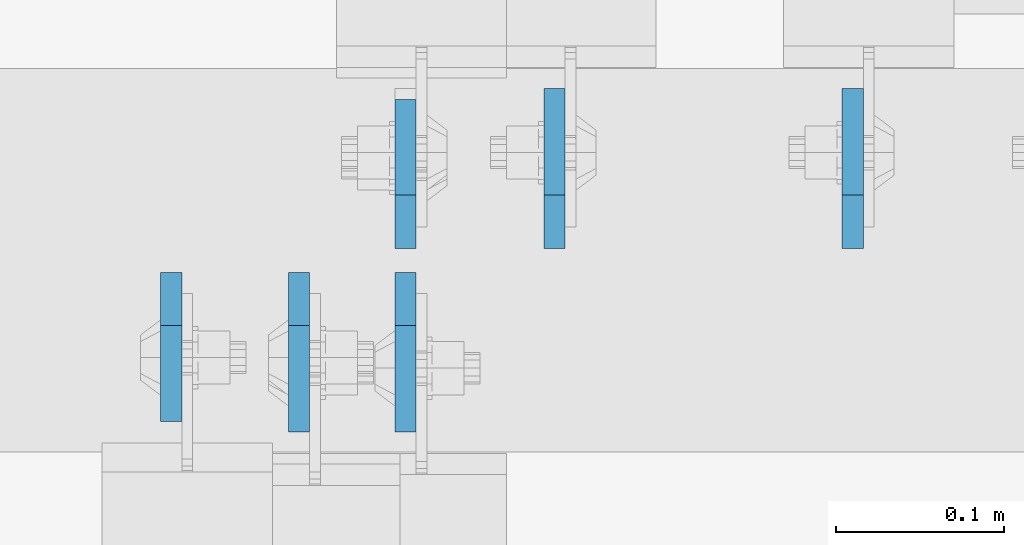
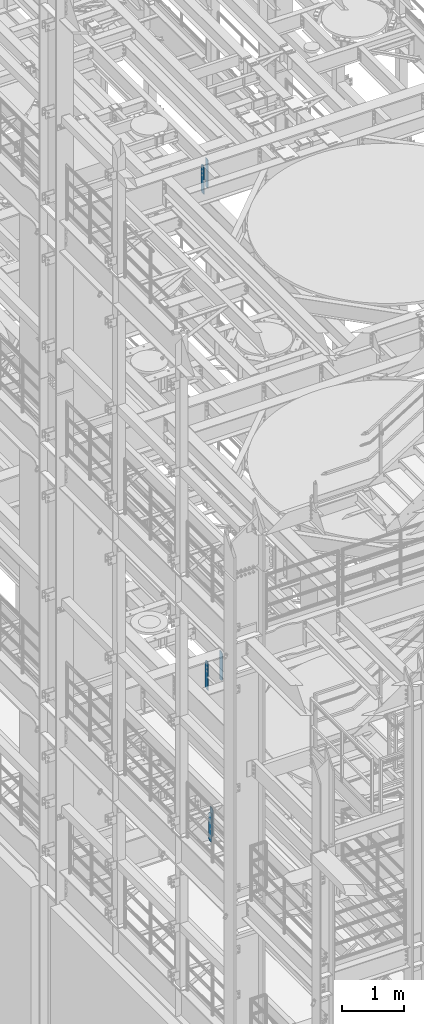
# One storey, part 1565 of 1876: 6 plates, 3 elements without a shape of their own.
"""IFC2X3 building model written with IfcOpenShell, lengths in millimetres."""

from ifc_helpers import new_model, si_unit, frame, origin_with_axes, place, context, subcontext, project, spatial, faceted_brep, material, type_object, element, aggregate, save


model = new_model("IFC2X3")

# Units and contexts
model_context = context("Model", 3, precision=1e-05, world=origin_with_axes())
body_context = subcontext(model_context, "Body", "Model", "MODEL_VIEW")
ifc_project = project(units=[si_unit("LENGTHUNIT", "METRE", prefix="MILLI"), si_unit("AREAUNIT", "SQUARE_METRE"), si_unit("VOLUMEUNIT", "CUBIC_METRE"), si_unit("MASSUNIT", "GRAM", prefix="KILO"), si_unit("TIMEUNIT", "SECOND"), si_unit("PLANEANGLEUNIT", "RADIAN"), si_unit("SOLIDANGLEUNIT", "STERADIAN"), si_unit("THERMODYNAMICTEMPERATUREUNIT", "DEGREE_CELSIUS"), si_unit("LUMINOUSINTENSITYUNIT", "LUMEN")], contexts=[model_context])

# Site, building, storey
site_placement = place(None, origin_with_axes())
site = spatial("IfcSite", under=ifc_project, at=site_placement, CompositionType="ELEMENT")
building_placement = place(site_placement, origin_with_axes())
building = spatial("IfcBuilding", under=site, at=building_placement, Name="Undefined", CompositionType="ELEMENT")
storey_placement = place(building_placement, origin_with_axes())
storey = spatial("IfcBuildingStorey", under=building, at=storey_placement, Name="Undefined", CompositionType="ELEMENT", Elevation=0.0)

# Assembly, plates
assembly_1_placement = place(storey_placement, origin_with_axes())
assembly_1 = element("IfcElementAssembly", 1, at=assembly_1_placement, inside=storey, Name="BEAM", AssemblyPlace="NOTDEFINED", PredefinedType="RIGID_FRAME")
ifc_material = material(Name="STEEL/A36")
plate_type_1 = type_object("IfcPlateType", PredefinedType="NOTDEFINED")
plate_1_placement = place(assembly_1_placement, frame((2708.27499990463, 1516.85625, 17386.3), z_axis=(0.0, 0.0, 1.0), x_axis=(0.0, -1.0, 0.0)))
plate_1 = element("IfcPlate", 2, at=plate_1_placement, type_object=plate_type_1, material=ifc_material, Name="PLATE", context=body_context, shape_type="Brep", body=[
    faceted_brep([(0.0, -6.34999999999991, 31.75), (0.0, -6.34999999999991, 539.75), (0.0, 6.34999999999991, 539.75), (0.0, 6.34999999999991, 31.75), (31.75, -6.34999999999991, 571.5), (31.75, 6.34999999999991, 571.5), (88.9000015258789, -6.34999999999991, 571.5), (88.9000015258789, 6.34999999999991, 571.5), (88.9000015258789, -6.34999999999991, 0.0), (88.9000015258789, 6.34999999999991, 0.0), (31.75, -6.34999999999991, 0.0), (31.75, 6.34999999999991, 0.0)], [[[0, 1, 2, 3]], [[1, 4, 5, 2]], [[4, 6, 7, 5]], [[6, 8, 9, 7]], [[8, 10, 11, 9]], [[10, 0, 3, 11]], [[5, 7, 9, 11, 3, 2]], [[10, 8, 6, 4, 1, 0]]]),
])
plate_2_placement = place(assembly_1_placement, frame((2847.97499990463, 1531.14375, 17386.3), z_axis=(0.0, 0.0, 1.0), x_axis=(0.0, 1.0, 0.0)))
plate_2 = element("IfcPlate", 3, at=plate_2_placement, type_object=plate_type_1, material=ifc_material, Name="PLATE", context=body_context, shape_type="Brep", body=[
    faceted_brep([(0.0, -6.34999999999991, 31.75), (0.0, -6.34999999999991, 539.75), (0.0, 6.34999999999991, 539.75), (0.0, 6.34999999999991, 31.75), (31.75, -6.34999999999991, 571.5), (31.75, 6.34999999999991, 571.5), (88.9000015258789, -6.34999999999991, 571.5), (88.9000015258789, 6.34999999999991, 571.5), (88.9000015258789, -6.34999999999991, 0.0), (88.9000015258789, 6.34999999999991, 0.0), (31.75, -6.34999999999991, 0.0), (31.75, 6.34999999999991, 0.0)], [[[0, 1, 2, 3]], [[1, 4, 5, 2]], [[4, 6, 7, 5]], [[6, 8, 9, 7]], [[8, 10, 11, 9]], [[10, 0, 3, 11]], [[5, 7, 9, 11, 3, 2]], [[10, 8, 6, 4, 1, 0]]]),
])
aggregate(assembly_1, [plate_1, plate_2])

assembly_2_placement = place(storey_placement, origin_with_axes())
assembly_2 = element("IfcElementAssembly", 4, at=assembly_2_placement, inside=storey, Name="BEAM", AssemblyPlace="NOTDEFINED", PredefinedType="RIGID_FRAME")
plate_type_2 = type_object("IfcPlateType", PredefinedType="NOTDEFINED")
plate_3_placement = place(assembly_2_placement, frame((2784.47499990463, 1516.85625, 7558.0875), z_axis=(0.0, 0.0, 1.0), x_axis=(0.0, -1.0, 0.0)))
plate_3 = element("IfcPlate", 5, at=plate_3_placement, type_object=plate_type_2, material=ifc_material, Name="PLATE", context=body_context, shape_type="Brep", body=[
    faceted_brep([(0.0, -6.34999999999991, 31.75), (0.0, -6.35000000000036, 538.162475585938), (0.0, 6.35000000000036, 538.162475585938), (0.0, 6.34999999999991, 31.75), (31.75, -6.35000000000036, 569.912475585938), (31.75, 6.35000000000036, 569.912475585938), (95.25, -6.35000000000036, 569.912475585938), (95.25, 6.35000000000036, 569.912475585938), (95.25, -6.35000000000036, 0.0), (95.25, 6.35000000000036, 0.0), (31.75, -6.34999999999991, 0.0), (31.75, 6.34999999999991, 0.0)], [[[0, 1, 2, 3]], [[1, 4, 5, 2]], [[4, 6, 7, 5]], [[6, 8, 9, 7]], [[8, 10, 11, 9]], [[10, 0, 3, 11]], [[5, 7, 9, 11, 3, 2]], [[10, 8, 6, 4, 1, 0]]]),
])
plate_4_placement = place(assembly_2_placement, frame((3114.67499990463, 1531.14375, 7558.0875), z_axis=(0.0, 0.0, 1.0), x_axis=(0.0, 1.0, 0.0)))
plate_4 = element("IfcPlate", 6, at=plate_4_placement, type_object=plate_type_2, material=ifc_material, Name="PLATE", context=body_context, shape_type="Brep", body=[
    faceted_brep([(0.0, -6.34999999999991, 31.75), (0.0, -6.35000000000036, 538.162475585938), (0.0, 6.35000000000036, 538.162475585938), (0.0, 6.34999999999991, 31.75), (31.75, -6.35000000000036, 569.912475585938), (31.75, 6.35000000000036, 569.912475585938), (95.25, -6.35000000000036, 569.912475585938), (95.25, 6.35000000000036, 569.912475585938), (95.25, -6.35000000000036, 0.0), (95.25, 6.35000000000036, 0.0), (31.75, -6.34999999999991, 0.0), (31.75, 6.34999999999991, 0.0)], [[[0, 1, 2, 3]], [[1, 4, 5, 2]], [[4, 6, 7, 5]], [[6, 8, 9, 7]], [[8, 10, 11, 9]], [[10, 0, 3, 11]], [[5, 7, 9, 11, 3, 2]], [[10, 8, 6, 4, 1, 0]]]),
])
aggregate(assembly_2, [plate_3, plate_4])

assembly_3_placement = place(storey_placement, origin_with_axes())
assembly_3 = element("IfcElementAssembly", 7, at=assembly_3_placement, inside=storey, Name="BEAM", AssemblyPlace="NOTDEFINED", PredefinedType="RIGID_FRAME")
plate_5_placement = place(assembly_3_placement, frame((2847.975, 1516.85625, 4535.4875), z_axis=(0.0, 0.0, 1.0), x_axis=(0.0, -1.0, 0.0)))
plate_5 = element("IfcPlate", 8, at=plate_5_placement, type_object=plate_type_2, material=ifc_material, Name="PLATE", context=body_context, shape_type="Brep", body=[
    faceted_brep([(0.0, -6.34999999999991, 31.75), (0.0, -6.35000000000036, 538.162475585938), (0.0, 6.35000000000036, 538.162475585938), (0.0, 6.34999999999991, 31.75), (31.75, -6.35000000000036, 569.912475585938), (31.75, 6.35000000000036, 569.912475585938), (95.25, -6.35000000000036, 569.912475585938), (95.25, 6.35000000000036, 569.912475585938), (95.25, -6.35000000000036, 0.0), (95.25, 6.35000000000036, 0.0), (31.75, -6.34999999999991, 0.0), (31.75, 6.34999999999991, 0.0)], [[[0, 1, 2, 3]], [[1, 4, 5, 2]], [[4, 6, 7, 5]], [[6, 8, 9, 7]], [[8, 10, 11, 9]], [[10, 0, 3, 11]], [[5, 7, 9, 11, 3, 2]], [[10, 8, 6, 4, 1, 0]]]),
])
plate_6_placement = place(assembly_3_placement, frame((2936.87499990463, 1531.14375, 4535.4875), z_axis=(0.0, 0.0, 1.0), x_axis=(0.0, 1.0, 0.0)))
plate_6 = element("IfcPlate", 9, at=plate_6_placement, type_object=plate_type_2, material=ifc_material, Name="PLATE", context=body_context, shape_type="Brep", body=[
    faceted_brep([(0.0, -6.34999999999991, 31.75), (0.0, -6.35000000000036, 538.162475585938), (0.0, 6.35000000000036, 538.162475585938), (0.0, 6.34999999999991, 31.75), (31.75, -6.35000000000036, 569.912475585938), (31.75, 6.35000000000036, 569.912475585938), (95.25, -6.35000000000036, 569.912475585938), (95.25, 6.35000000000036, 569.912475585938), (95.25, -6.35000000000036, 0.0), (95.25, 6.35000000000036, 0.0), (31.75, -6.34999999999991, 0.0), (31.75, 6.34999999999991, 0.0)], [[[0, 1, 2, 3]], [[1, 4, 5, 2]], [[4, 6, 7, 5]], [[6, 8, 9, 7]], [[8, 10, 11, 9]], [[10, 0, 3, 11]], [[5, 7, 9, 11, 3, 2]], [[10, 8, 6, 4, 1, 0]]]),
])
aggregate(assembly_3, [plate_5, plate_6])

save(model, "model.ifc")
